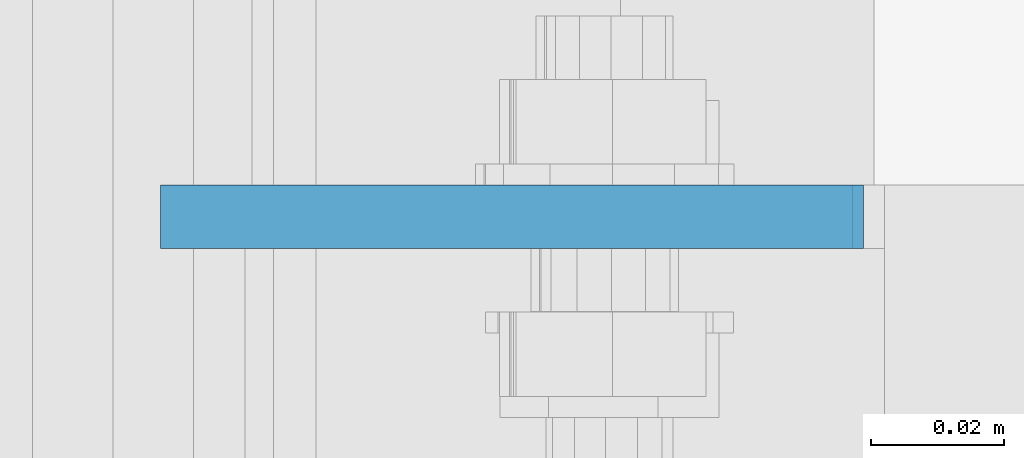
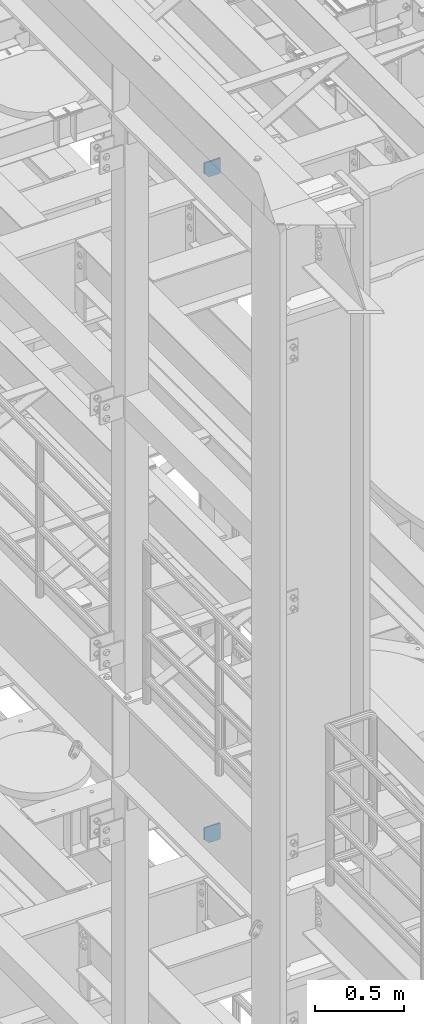
# One storey, part 1476 of 1876: 2 plates, 2 elements without a shape of their own.
"""IFC2X3 building model written with IfcOpenShell, lengths in millimetres."""

import ifcopenshell
import ifcopenshell.guid

model = None  # the IFC model being written
_history = None  # IfcOwnerHistory: only IFC2X3 demands one
_inside = {}  # id of a spatial element -> (the spatial element, [elements in it])
_under = {}  # id of a project, library or spatial element -> (it, [spatial elements below it])
_declared = {}  # id of a project -> (the project, [libraries it declares])
_typed = {}  # id of a type object -> (the type object, [elements of that type])
_made_of = {}  # id of a material, layer set ... -> (it, [elements and type objects made of it])


def new_model(schema):
    """Start an empty IFC model of exactly this schema.

    Asked for "IFC4X3", IfcOpenShell would pick the latest addendum, in which some entities
    have other attributes; the version numbers below select the first issue.
    IFC2X3 requires an IfcOwnerHistory on every rooted entity: one is made here for all.
    """
    global model, _history
    if schema == "IFC4X3":
        model = ifcopenshell.file(schema_version=(4, 3, 0, 0))
    else:
        model = ifcopenshell.file(schema=schema)
    _inside.clear()
    _under.clear()
    _declared.clear()
    _typed.clear()
    _made_of.clear()
    _history = None
    if model.schema == "IFC2X3":
        org = make("IfcOrganization", Name="unknown")
        user = make(
            "IfcPersonAndOrganization",
            ThePerson=make("IfcPerson", FamilyName="unknown"),
            TheOrganization=org,
        )
        app = make(
            "IfcApplication",
            ApplicationDeveloper=org,
            Version="unknown",
            ApplicationFullName="unknown",
            ApplicationIdentifier="unknown",
        )
        _history = make(
            "IfcOwnerHistory",
            OwningUser=user,
            OwningApplication=app,
            ChangeAction="ADDED",
            CreationDate=0,
        )
    return model


def make(cls, **values):
    """One entity of the class cls with the attributes given. An attribute that is None is left unset."""
    return model.create_entity(
        cls, **{name: value for name, value in values.items() if value is not None}
    )


def rooted(cls, **values):
    """An entity with a GlobalId (a new one), such as an element, a storey or a relation."""
    return make(cls, GlobalId=ifcopenshell.guid.new(), OwnerHistory=_history, **values)


def si_unit(unit_type, name, prefix=None):
    """IfcSIUnit, for example si_unit("LENGTHUNIT", "METRE", prefix="MILLI")."""
    return make("IfcSIUnit", UnitType=unit_type, Prefix=prefix, Name=name)


def assignment(units):
    """IfcUnitAssignment: the units of a project."""
    return None if units is None else make("IfcUnitAssignment", Units=units)


def point(xyz):
    """IfcCartesianPoint."""
    return None if xyz is None else make("IfcCartesianPoint", Coordinates=xyz)


def direction(xyz):
    """IfcDirection."""
    return None if xyz is None else make("IfcDirection", DirectionRatios=xyz)


def frame(location, z_axis=None, x_axis=None):
    """IfcAxis2Placement3D, a coordinate frame: its origin and axes. An axis left out is left unset."""
    return make(
        "IfcAxis2Placement3D",
        Location=point(location),
        Axis=direction(z_axis),
        RefDirection=direction(x_axis),
    )


def origin_with_axes():
    """The frame at (0, 0, 0) with the z axis (0, 0, 1) and the x axis (1, 0, 0) written out."""
    return frame((0.0, 0.0, 0.0), z_axis=(0.0, 0.0, 1.0), x_axis=(1.0, 0.0, 0.0))


def place(relative_to, where):
    """IfcLocalPlacement: puts the frame where relative to a parent placement (None: the world)."""
    return make(
        "IfcLocalPlacement", PlacementRelTo=relative_to, RelativePlacement=where
    )


def context(
    kind, dimensions, precision=None, world=None, true_north=None, identifier=None
):
    """IfcGeometricRepresentationContext, for example the 3D "Model" context."""
    return make(
        "IfcGeometricRepresentationContext",
        ContextIdentifier=identifier,
        ContextType=kind,
        CoordinateSpaceDimension=dimensions,
        Precision=precision,
        WorldCoordinateSystem=world,
        TrueNorth=true_north,
    )


def subcontext(parent, identifier, kind, view, scale=None):
    """IfcGeometricRepresentationSubContext, for example "Body" below "Model"."""
    return make(
        "IfcGeometricRepresentationSubContext",
        ContextIdentifier=identifier,
        ContextType=kind,
        ParentContext=parent,
        TargetScale=scale,
        TargetView=view,
    )


def project(units=None, contexts=None):
    """IfcProject with its units and contexts."""
    return rooted(
        "IfcProject",
        Name="project",
        RepresentationContexts=contexts,
        UnitsInContext=assignment(units),
    )


def spatial(cls, under=None, at=None, **own):
    """A site, building, storey or space (cls), placed at a placement, below another one or the project."""
    s = rooted(cls, ObjectPlacement=at, **own)
    if under is not None:
        _under.setdefault(under.id(), (under, []))[1].append(s)
    return s


def faces_of(points, faces, orient=None, outer=None):
    """IfcFace entities. A face is a list of loops; a loop is a list of indices into points, from 0.

    orient and outer hold one flag for each loop. By default every Orientation is true, the
    first loop of a face is its IfcFaceOuterBound and the others are IfcFaceBound.
    """
    made = []
    for i, loops in enumerate(faces):
        bounds = []
        for j, loop in enumerate(loops):
            is_outer = j == 0 if outer is None else outer[i][j]
            bounds.append(
                make(
                    "IfcFaceOuterBound" if is_outer else "IfcFaceBound",
                    Bound=make("IfcPolyLoop", Polygon=[points[k] for k in loop]),
                    Orientation=True if orient is None else orient[i][j],
                )
            )
        made.append(make("IfcFace", Bounds=bounds))
    return made


def faceted_brep(points, faces, orient=None, outer=None, voids=None):
    """IfcFacetedBrep: a solid bounded by flat faces; with voids (closed shells), ...WithVoids."""
    shared = [point(p) for p in points]
    hull = make("IfcClosedShell", CfsFaces=faces_of(shared, faces, orient, outer))
    if voids is None:
        return make("IfcFacetedBrep", Outer=hull)
    return make(
        "IfcFacetedBrepWithVoids",
        Outer=hull,
        Voids=[
            make(cls, CfsFaces=faces_of(shared, fs, o, b)) for cls, fs, o, b in voids
        ],
    )


def shape(context_of_items, identifier, shape_type, items):
    """IfcShapeRepresentation: the items that make up one representation, for example the "Body"."""
    return make(
        "IfcShapeRepresentation",
        ContextOfItems=context_of_items,
        RepresentationIdentifier=identifier,
        RepresentationType=shape_type,
        Items=items,
    )


def material(Name=None, Category=None):
    """IfcMaterial."""
    return make("IfcMaterial", Name=Name, Category=Category)


def made_of(thing, what):
    """Note that an element or type object is made of a material, layer set ...; save() writes the relation."""
    if what is not None:
        _made_of.setdefault(what.id(), (what, []))[1].append(thing)
    return thing


def type_object(cls, material=None, **own):
    """A type object (cls), such as IfcWallType, which elements share."""
    return made_of(rooted(cls, **own), material)


def element(
    cls,
    number,
    at=None,
    inside=None,
    cuts=None,
    type_object=None,
    material=None,
    context=None,
    identifier="Body",
    shape_type=None,
    held_by="IfcProductDefinitionShape",
    body=None,
    shapes=None,
    **own,
):
    """One element of the class cls, such as IfcWall. Its Tag is "e" and its number.

    at: its placement. inside: the storey or other place that contains it. cuts: it is an
    opening in that element (IfcRelVoidsElement). A single representation is given by context,
    identifier, shape_type and body (its items); several are given by shapes. held_by: the class
    of the entity that holds the representations. save() writes the other relations.
    """
    e = rooted(cls, Tag="e%d" % number, ObjectPlacement=at, **own)
    if body is not None:
        shapes = [shape(context, identifier, shape_type, body)]
    if shapes is not None:
        e.Representation = make(held_by, Representations=shapes)
    if inside is not None:
        _inside.setdefault(inside.id(), (inside, []))[1].append(e)
    if cuts is not None:
        rooted(
            "IfcRelVoidsElement", RelatingBuildingElement=cuts, RelatedOpeningElement=e
        )
    if type_object is not None:
        _typed.setdefault(type_object.id(), (type_object, []))[1].append(e)
    return made_of(e, material)


def aggregate(whole, parts):
    """IfcRelAggregates: a whole, such as a stair, and the parts it consists of."""
    return rooted("IfcRelAggregates", RelatingObject=whole, RelatedObjects=parts)


def save(model, path):
    """Write the relations noted so far, then the file.

    IfcRelAggregates (storeys below a building ...), IfcRelContainedInSpatialStructure (elements
    in a storey), IfcRelDefinesByType, IfcRelAssociatesMaterial and IfcRelDeclares: one each for
    every whole, place, type object, material and project.
    """
    for whole, parts in _under.values():
        aggregate(whole, parts)
    for where, things in _inside.values():
        rooted(
            "IfcRelContainedInSpatialStructure",
            RelatedElements=things,
            RelatingStructure=where,
        )
    for kind, things in _typed.values():
        rooted("IfcRelDefinesByType", RelatedObjects=things, RelatingType=kind)
    for what, things in _made_of.values():
        rooted("IfcRelAssociatesMaterial", RelatedObjects=things, RelatingMaterial=what)
    for by, libraries in _declared.values():
        rooted("IfcRelDeclares", RelatingContext=by, RelatedDefinitions=libraries)
    model.write(path)


model = new_model("IFC2X3")

# Units and contexts
model_context = context("Model", 3, precision=1e-05, world=origin_with_axes())
body_context = subcontext(model_context, "Body", "Model", "MODEL_VIEW")
ifc_project = project(units=[si_unit("LENGTHUNIT", "METRE", prefix="MILLI"), si_unit("AREAUNIT", "SQUARE_METRE"), si_unit("VOLUMEUNIT", "CUBIC_METRE"), si_unit("MASSUNIT", "GRAM", prefix="KILO"), si_unit("TIMEUNIT", "SECOND"), si_unit("PLANEANGLEUNIT", "RADIAN"), si_unit("SOLIDANGLEUNIT", "STERADIAN"), si_unit("THERMODYNAMICTEMPERATUREUNIT", "DEGREE_CELSIUS"), si_unit("LUMINOUSINTENSITYUNIT", "LUMEN")], contexts=[model_context])

# Site, building, storey
site_placement = place(None, origin_with_axes())
site = spatial("IfcSite", under=ifc_project, at=site_placement, CompositionType="ELEMENT")
building_placement = place(site_placement, origin_with_axes())
building = spatial("IfcBuilding", under=site, at=building_placement, Name="Undefined", CompositionType="ELEMENT")
storey_placement = place(building_placement, origin_with_axes())
storey = spatial("IfcBuildingStorey", under=building, at=storey_placement, Name="Undefined", CompositionType="ELEMENT", Elevation=0.0)

# Assembly, plate
assembly_1_placement = place(storey_placement, origin_with_axes())
assembly_1 = element("IfcElementAssembly", 1, at=assembly_1_placement, inside=storey, Name="BEAM", AssemblyPlace="NOTDEFINED", PredefinedType="RIGID_FRAME")
ifc_material = material(Name="STEEL/A36")
plate_type = type_object("IfcPlateType", PredefinedType="NOTDEFINED")
plate_1_placement = place(assembly_1_placement, frame((111.128498160898, -3357.5625, 17386.3), z_axis=(-1.0, 0.0, 0.0), x_axis=(0.0, 0.0, 1.0)))
plate_1 = element("IfcPlate", 2, at=plate_1_placement, type_object=plate_type, material=ifc_material, Name="PLATE", context=body_context, shape_type="Brep", body=[
    faceted_brep([(0.0, -4.76249999999982, 0.0), (0.0, -4.76249999999982, 72.234748840332), (0.0, 4.76249999999982, 72.234748840332), (0.0, 4.76249999999982, 0.0), (31.75, -4.76249999999982, 103.984748840332), (31.75, 4.76249999999982, 103.984748840332), (111.653274536133, -4.76249999999982, 103.984748840332), (111.653274536133, 4.76249999999982, 103.984748840332), (111.653274536133, -4.76249999999982, 0.0), (111.653274536133, 4.76249999999982, 0.0)], [[[0, 1, 2, 3]], [[1, 4, 5, 2]], [[4, 6, 7, 5]], [[6, 8, 9, 7]], [[8, 0, 3, 9]], [[5, 7, 9, 3, 2]], [[8, 6, 4, 1, 0]]]),
])
aggregate(assembly_1, [plate_1])

assembly_2_placement = place(storey_placement, origin_with_axes())
assembly_2 = element("IfcElementAssembly", 3, at=assembly_2_placement, inside=storey, Name="BEAM", AssemblyPlace="NOTDEFINED", PredefinedType="RIGID_FRAME")
plate_2_placement = place(assembly_2_placement, frame((7.14374999999999, -3357.5625, 21958.3), z_axis=(0.0, 0.0, 1.0), x_axis=(1.0, 0.0, 0.0)))
plate_2 = element("IfcPlate", 4, at=plate_2_placement, type_object=plate_type, material=ifc_material, Name="PLATE", context=body_context, shape_type="Brep", body=[
    faceted_brep([(-9.76996261670138e-14, -4.76250000000073, 31.75), (-3.4106151360902e-06, -4.76249999999982, 104.420860290527), (-3.4106151360902e-06, 4.76249999999982, 104.420860290527), (-9.76996261670138e-14, 4.76250000000073, 31.75), (105.552177429199, -4.76249999999982, 104.420860290527), (105.552177429199, 4.76249999999982, 104.420860290527), (105.552177429199, -4.76249999999982, 0.0), (105.552177429199, 4.76249999999982, 0.0), (31.75, -4.76250000000073, 0.0), (31.75, 4.76250000000073, 0.0)], [[[0, 1, 2, 3]], [[1, 4, 5, 2]], [[4, 6, 7, 5]], [[6, 8, 9, 7]], [[8, 0, 3, 9]], [[5, 7, 9, 3, 2]], [[8, 6, 4, 1, 0]]]),
])
aggregate(assembly_2, [plate_2])

save(model, "model.ifc")
